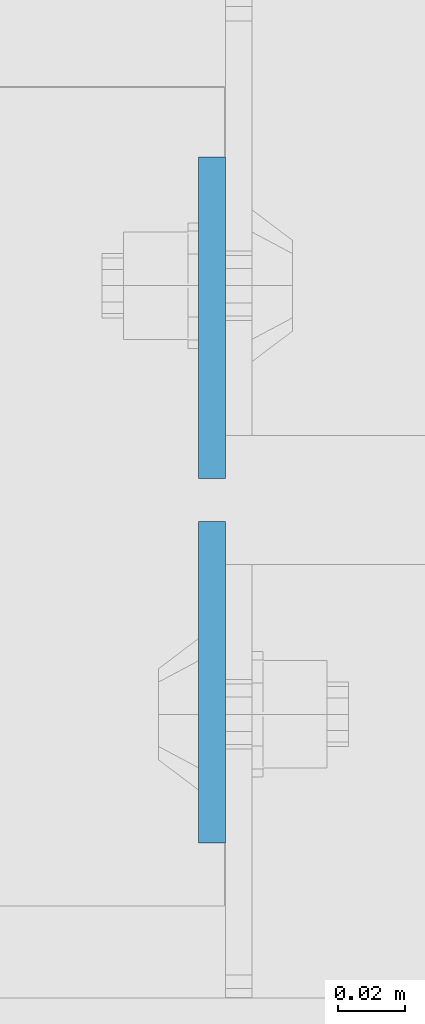
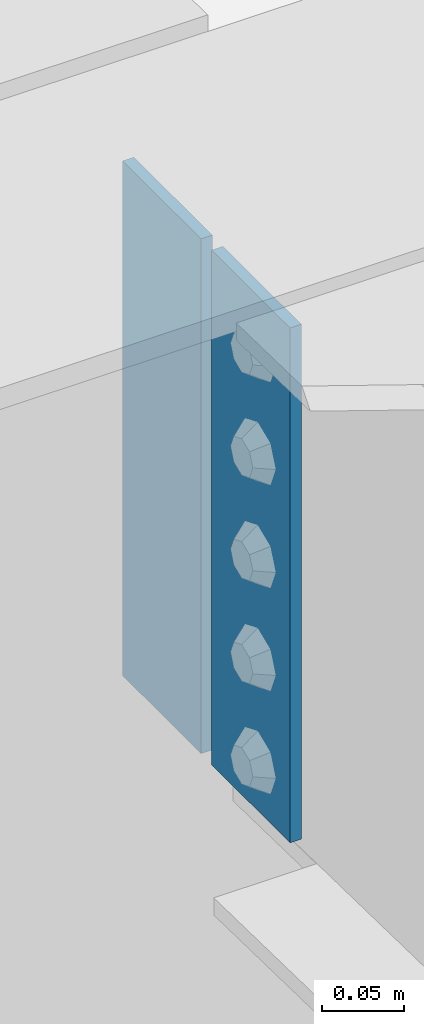
# One storey, part 1533 of 1763: 2 plates, 1 element without a shape of its own.
"""IFC2X3 building model written with IfcOpenShell, lengths in millimetres."""

import ifcopenshell
import ifcopenshell.guid

model = None  # the IFC model being written
_history = None  # IfcOwnerHistory: only IFC2X3 demands one
_inside = {}  # id of a spatial element -> (the spatial element, [elements in it])
_under = {}  # id of a project, library or spatial element -> (it, [spatial elements below it])
_declared = {}  # id of a project -> (the project, [libraries it declares])
_typed = {}  # id of a type object -> (the type object, [elements of that type])
_made_of = {}  # id of a material, layer set ... -> (it, [elements and type objects made of it])


def new_model(schema):
    """Start an empty IFC model of exactly this schema.

    Asked for "IFC4X3", IfcOpenShell would pick the latest addendum, in which some entities
    have other attributes; the version numbers below select the first issue.
    IFC2X3 requires an IfcOwnerHistory on every rooted entity: one is made here for all.
    """
    global model, _history
    if schema == "IFC4X3":
        model = ifcopenshell.file(schema_version=(4, 3, 0, 0))
    else:
        model = ifcopenshell.file(schema=schema)
    _inside.clear()
    _under.clear()
    _declared.clear()
    _typed.clear()
    _made_of.clear()
    _history = None
    if model.schema == "IFC2X3":
        org = make("IfcOrganization", Name="unknown")
        user = make(
            "IfcPersonAndOrganization",
            ThePerson=make("IfcPerson", FamilyName="unknown"),
            TheOrganization=org,
        )
        app = make(
            "IfcApplication",
            ApplicationDeveloper=org,
            Version="unknown",
            ApplicationFullName="unknown",
            ApplicationIdentifier="unknown",
        )
        _history = make(
            "IfcOwnerHistory",
            OwningUser=user,
            OwningApplication=app,
            ChangeAction="ADDED",
            CreationDate=0,
        )
    return model


def make(cls, **values):
    """One entity of the class cls with the attributes given. An attribute that is None is left unset."""
    return model.create_entity(
        cls, **{name: value for name, value in values.items() if value is not None}
    )


def rooted(cls, **values):
    """An entity with a GlobalId (a new one), such as an element, a storey or a relation."""
    return make(cls, GlobalId=ifcopenshell.guid.new(), OwnerHistory=_history, **values)


def si_unit(unit_type, name, prefix=None):
    """IfcSIUnit, for example si_unit("LENGTHUNIT", "METRE", prefix="MILLI")."""
    return make("IfcSIUnit", UnitType=unit_type, Prefix=prefix, Name=name)


def assignment(units):
    """IfcUnitAssignment: the units of a project."""
    return None if units is None else make("IfcUnitAssignment", Units=units)


def point(xyz):
    """IfcCartesianPoint."""
    return None if xyz is None else make("IfcCartesianPoint", Coordinates=xyz)


def direction(xyz):
    """IfcDirection."""
    return None if xyz is None else make("IfcDirection", DirectionRatios=xyz)


def frame(location, z_axis=None, x_axis=None):
    """IfcAxis2Placement3D, a coordinate frame: its origin and axes. An axis left out is left unset."""
    return make(
        "IfcAxis2Placement3D",
        Location=point(location),
        Axis=direction(z_axis),
        RefDirection=direction(x_axis),
    )


def origin_with_axes():
    """The frame at (0, 0, 0) with the z axis (0, 0, 1) and the x axis (1, 0, 0) written out."""
    return frame((0.0, 0.0, 0.0), z_axis=(0.0, 0.0, 1.0), x_axis=(1.0, 0.0, 0.0))


def place(relative_to, where):
    """IfcLocalPlacement: puts the frame where relative to a parent placement (None: the world)."""
    return make(
        "IfcLocalPlacement", PlacementRelTo=relative_to, RelativePlacement=where
    )


def context(
    kind, dimensions, precision=None, world=None, true_north=None, identifier=None
):
    """IfcGeometricRepresentationContext, for example the 3D "Model" context."""
    return make(
        "IfcGeometricRepresentationContext",
        ContextIdentifier=identifier,
        ContextType=kind,
        CoordinateSpaceDimension=dimensions,
        Precision=precision,
        WorldCoordinateSystem=world,
        TrueNorth=true_north,
    )


def subcontext(parent, identifier, kind, view, scale=None):
    """IfcGeometricRepresentationSubContext, for example "Body" below "Model"."""
    return make(
        "IfcGeometricRepresentationSubContext",
        ContextIdentifier=identifier,
        ContextType=kind,
        ParentContext=parent,
        TargetScale=scale,
        TargetView=view,
    )


def project(units=None, contexts=None):
    """IfcProject with its units and contexts."""
    return rooted(
        "IfcProject",
        Name="project",
        RepresentationContexts=contexts,
        UnitsInContext=assignment(units),
    )


def spatial(cls, under=None, at=None, **own):
    """A site, building, storey or space (cls), placed at a placement, below another one or the project."""
    s = rooted(cls, ObjectPlacement=at, **own)
    if under is not None:
        _under.setdefault(under.id(), (under, []))[1].append(s)
    return s


def faces_of(points, faces, orient=None, outer=None):
    """IfcFace entities. A face is a list of loops; a loop is a list of indices into points, from 0.

    orient and outer hold one flag for each loop. By default every Orientation is true, the
    first loop of a face is its IfcFaceOuterBound and the others are IfcFaceBound.
    """
    made = []
    for i, loops in enumerate(faces):
        bounds = []
        for j, loop in enumerate(loops):
            is_outer = j == 0 if outer is None else outer[i][j]
            bounds.append(
                make(
                    "IfcFaceOuterBound" if is_outer else "IfcFaceBound",
                    Bound=make("IfcPolyLoop", Polygon=[points[k] for k in loop]),
                    Orientation=True if orient is None else orient[i][j],
                )
            )
        made.append(make("IfcFace", Bounds=bounds))
    return made


def faceted_brep(points, faces, orient=None, outer=None, voids=None):
    """IfcFacetedBrep: a solid bounded by flat faces; with voids (closed shells), ...WithVoids."""
    shared = [point(p) for p in points]
    hull = make("IfcClosedShell", CfsFaces=faces_of(shared, faces, orient, outer))
    if voids is None:
        return make("IfcFacetedBrep", Outer=hull)
    return make(
        "IfcFacetedBrepWithVoids",
        Outer=hull,
        Voids=[
            make(cls, CfsFaces=faces_of(shared, fs, o, b)) for cls, fs, o, b in voids
        ],
    )


def shape(context_of_items, identifier, shape_type, items):
    """IfcShapeRepresentation: the items that make up one representation, for example the "Body"."""
    return make(
        "IfcShapeRepresentation",
        ContextOfItems=context_of_items,
        RepresentationIdentifier=identifier,
        RepresentationType=shape_type,
        Items=items,
    )


def material(Name=None, Category=None):
    """IfcMaterial."""
    return make("IfcMaterial", Name=Name, Category=Category)


def made_of(thing, what):
    """Note that an element or type object is made of a material, layer set ...; save() writes the relation."""
    if what is not None:
        _made_of.setdefault(what.id(), (what, []))[1].append(thing)
    return thing


def type_object(cls, material=None, **own):
    """A type object (cls), such as IfcWallType, which elements share."""
    return made_of(rooted(cls, **own), material)


def element(
    cls,
    number,
    at=None,
    inside=None,
    cuts=None,
    type_object=None,
    material=None,
    context=None,
    identifier="Body",
    shape_type=None,
    held_by="IfcProductDefinitionShape",
    body=None,
    shapes=None,
    **own,
):
    """One element of the class cls, such as IfcWall. Its Tag is "e" and its number.

    at: its placement. inside: the storey or other place that contains it. cuts: it is an
    opening in that element (IfcRelVoidsElement). A single representation is given by context,
    identifier, shape_type and body (its items); several are given by shapes. held_by: the class
    of the entity that holds the representations. save() writes the other relations.
    """
    e = rooted(cls, Tag="e%d" % number, ObjectPlacement=at, **own)
    if body is not None:
        shapes = [shape(context, identifier, shape_type, body)]
    if shapes is not None:
        e.Representation = make(held_by, Representations=shapes)
    if inside is not None:
        _inside.setdefault(inside.id(), (inside, []))[1].append(e)
    if cuts is not None:
        rooted(
            "IfcRelVoidsElement", RelatingBuildingElement=cuts, RelatedOpeningElement=e
        )
    if type_object is not None:
        _typed.setdefault(type_object.id(), (type_object, []))[1].append(e)
    return made_of(e, material)


def aggregate(whole, parts):
    """IfcRelAggregates: a whole, such as a stair, and the parts it consists of."""
    return rooted("IfcRelAggregates", RelatingObject=whole, RelatedObjects=parts)


def save(model, path):
    """Write the relations noted so far, then the file.

    IfcRelAggregates (storeys below a building ...), IfcRelContainedInSpatialStructure (elements
    in a storey), IfcRelDefinesByType, IfcRelAssociatesMaterial and IfcRelDeclares: one each for
    every whole, place, type object, material and project.
    """
    for whole, parts in _under.values():
        aggregate(whole, parts)
    for where, things in _inside.values():
        rooted(
            "IfcRelContainedInSpatialStructure",
            RelatedElements=things,
            RelatingStructure=where,
        )
    for kind, things in _typed.values():
        rooted("IfcRelDefinesByType", RelatedObjects=things, RelatingType=kind)
    for what, things in _made_of.values():
        rooted("IfcRelAssociatesMaterial", RelatedObjects=things, RelatingMaterial=what)
    for by, libraries in _declared.values():
        rooted("IfcRelDeclares", RelatingContext=by, RelatedDefinitions=libraries)
    model.write(path)


model = new_model("IFC2X3")

# Units and contexts
model_context = context("Model", 3, precision=1e-05, world=origin_with_axes())
body_context = subcontext(model_context, "Body", "Model", "MODEL_VIEW")
ifc_project = project(units=[si_unit("LENGTHUNIT", "METRE", prefix="MILLI"), si_unit("AREAUNIT", "SQUARE_METRE"), si_unit("VOLUMEUNIT", "CUBIC_METRE"), si_unit("MASSUNIT", "GRAM", prefix="KILO"), si_unit("TIMEUNIT", "SECOND"), si_unit("PLANEANGLEUNIT", "RADIAN"), si_unit("SOLIDANGLEUNIT", "STERADIAN"), si_unit("THERMODYNAMICTEMPERATUREUNIT", "DEGREE_CELSIUS"), si_unit("LUMINOUSINTENSITYUNIT", "LUMEN")], contexts=[model_context])

# Site, building, storey
site_placement = place(None, origin_with_axes())
site = spatial("IfcSite", under=ifc_project, at=site_placement, CompositionType="ELEMENT")
building_placement = place(site_placement, origin_with_axes())
building = spatial("IfcBuilding", under=site, at=building_placement, Name="Undefined", CompositionType="ELEMENT")
storey_placement = place(building_placement, origin_with_axes())
storey = spatial("IfcBuildingStorey", under=building, at=storey_placement, Name="Undefined", CompositionType="ELEMENT", Elevation=0.0)

# Assembly, plates
assembly_placement = place(storey_placement, origin_with_axes())
assembly = element("IfcElementAssembly", 1, at=assembly_placement, inside=storey, Name="BEAM", AssemblyPlace="NOTDEFINED", PredefinedType="RIGID_FRAME")
ifc_material = material(Name="STEEL/A36")
plate_type = type_object("IfcPlateType", PredefinedType="NOTDEFINED")
plate_1_placement = place(assembly_placement, frame((-57538.3750236983, 13684.249999996, 11580.6599836165), z_axis=(0.0, -1.0, 0.0), x_axis=(0.0, 0.0, -1.0)))
plate_1 = element("IfcPlate", 2, at=plate_1_placement, type_object=plate_type, material=ifc_material, Name="PLATE", context=body_context, shape_type="Brep", body=[
    faceted_brep([(0.0, -3.96900000000096, 0.0), (0.0, -3.96900000000096, 95.25), (0.0, 3.96900000000096, 95.25), (0.0, 3.96900000000096, 0.0), (381.0, -3.96899999999732, 95.25), (381.0, 3.96899999999732, 95.25), (381.0, -3.96900000001915, 3.34694050252438e-10), (381.0, 3.9690000000046, 3.20142135024071e-10)], [[[0, 1, 2, 3]], [[1, 4, 5, 2]], [[4, 6, 7, 5]], [[6, 0, 3, 7]], [[5, 7, 3, 2]], [[6, 4, 1, 0]]]),
])
plate_2_placement = place(assembly_placement, frame((-57538.3750236984, 13696.949999996, 11581.1806250726), z_axis=(0.0, 1.0, 0.0), x_axis=(0.0, 0.0, -1.0)))
plate_2 = element("IfcPlate", 3, at=plate_2_placement, type_object=plate_type, material=ifc_material, Name="PLATE", context=body_context, shape_type="Brep", body=[
    faceted_brep([(0.0, -3.96900000000096, 0.0), (0.0, -3.96900000000096, 95.25), (0.0, 3.96900000000096, 95.25), (0.0, 3.96900000000096, 0.0), (381.0, -3.96899999999732, 95.25), (381.0, 3.96899999999732, 95.25), (381.0, -3.96900000001915, 3.34694050252438e-10), (381.0, 3.9690000000046, 3.20142135024071e-10)], [[[0, 1, 2, 3]], [[1, 4, 5, 2]], [[4, 6, 7, 5]], [[6, 0, 3, 7]], [[5, 7, 3, 2]], [[6, 4, 1, 0]]]),
])
aggregate(assembly, [plate_1, plate_2])

save(model, "model.ifc")
